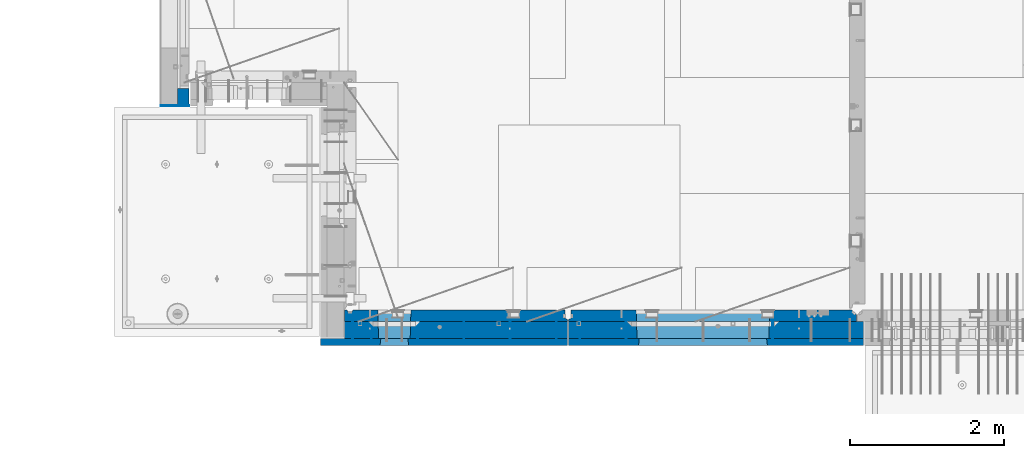
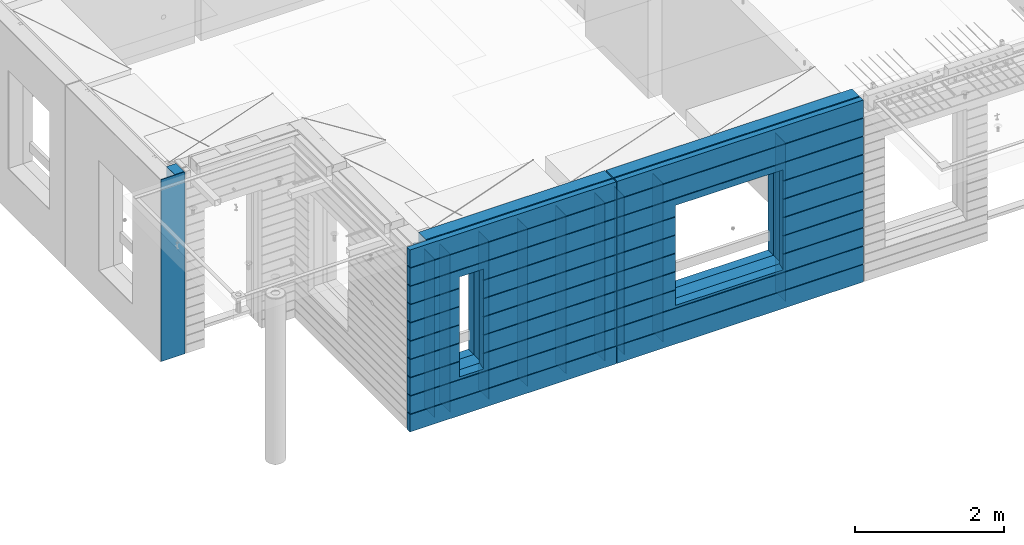
# One storey, part 227 of 352: 17 walls, 3 elements without a shape of their own.
"""IFC2X3 building model written with IfcOpenShell, lengths in millimetres."""

from ifc_helpers import new_model, si_unit, frame, origin_with_axes, place, context, subcontext, project, spatial, faceted_brep, material, type_object, element, aggregate, save


model = new_model("IFC2X3")

# Units and contexts
model_context = context("Model", 3, precision=1e-05, world=origin_with_axes())
body_context = subcontext(model_context, "Body", "Model", "MODEL_VIEW")
ifc_project = project(units=[si_unit("LENGTHUNIT", "METRE", prefix="MILLI"), si_unit("AREAUNIT", "SQUARE_METRE"), si_unit("VOLUMEUNIT", "CUBIC_METRE"), si_unit("MASSUNIT", "GRAM", prefix="KILO"), si_unit("TIMEUNIT", "SECOND"), si_unit("PLANEANGLEUNIT", "RADIAN"), si_unit("SOLIDANGLEUNIT", "STERADIAN"), si_unit("THERMODYNAMICTEMPERATUREUNIT", "DEGREE_CELSIUS"), si_unit("LUMINOUSINTENSITYUNIT", "LUMEN")], contexts=[model_context])

# Site, building, storey
site_placement = place(None, origin_with_axes())
site = spatial("IfcSite", under=ifc_project, at=site_placement, CompositionType="ELEMENT")
building_placement = place(site_placement, origin_with_axes())
building = spatial("IfcBuilding", under=site, at=building_placement, CompositionType="ELEMENT")
storey_placement = place(building_placement, origin_with_axes())
storey = spatial("IfcBuildingStorey", under=building, at=storey_placement, Name="6", CompositionType="ELEMENT", Elevation=0.0)

# Assembly, walls
assembly_1_placement = place(storey_placement, origin_with_axes())
assembly_1 = element("IfcElementAssembly", 1, at=assembly_1_placement, inside=storey, AssemblyPlace="NOTDEFINED", PredefinedType="REINFORCEMENT_UNIT")
ifc_material_1 = material(Name="Undefined")
wall_type_1 = type_object("IfcWallType", PredefinedType="NOTDEFINED")
wall_1_placement = place(assembly_1_placement, frame((10122.5, 7880.0, 98115.0), z_axis=(0.0, 0.0, 1.0), x_axis=(0.0, -1.0, 0.0)))
wall_1 = element("IfcWall", 2, at=wall_1_placement, type_object=wall_type_1, material=ifc_material_1, Name="(PD)", context=body_context, shape_type="Brep", body=[
    faceted_brep([(0.0, 5.0, -1300.0), (0.0, 5.0, 1300.0), (280.0, 5.0, 1300.0), (280.0, 5.0, -1300.0), (0.0, -5.0, 1300.0), (280.0, -5.0, 1300.0), (0.0, -5.0, -1300.0), (280.0, -5.0, -1300.0)], [[[0, 1, 2, 3]], [[1, 4, 5, 2]], [[4, 6, 7, 5]], [[6, 0, 3, 7]], [[5, 7, 3, 2]], [[6, 4, 1, 0]]]),
])
wall_2_placement = place(assembly_1_placement, frame((10362.5, 7880.0, 98115.0), z_axis=(0.0, 0.0, 1.0), x_axis=(0.0, -1.0, 0.0)))
wall_2 = element("IfcWall", 3, at=wall_2_placement, type_object=wall_type_1, material=ifc_material_1, Name="(PD)", context=body_context, shape_type="Brep", body=[
    faceted_brep([(0.0, 5.0, -1300.0), (0.0, 5.0, 1300.0), (280.0, 5.0, 1300.0), (280.0, 5.0, -1300.0), (0.0, -5.0, 1300.0), (280.0, -5.0, 1300.0), (0.0, -5.0, -1300.0), (280.0, -5.0, -1300.0)], [[[0, 1, 2, 3]], [[1, 4, 5, 2]], [[4, 6, 7, 5]], [[6, 0, 3, 7]], [[5, 7, 3, 2]], [[6, 4, 1, 0]]]),
])
wall_3_placement = place(assembly_1_placement, frame((10962.5, 7880.0, 98115.0), z_axis=(0.0, 0.0, 1.0), x_axis=(0.0, -1.0, 0.0)))
wall_3 = element("IfcWall", 4, at=wall_3_placement, type_object=wall_type_1, material=ifc_material_1, Name="(PD)", context=body_context, shape_type="Brep", body=[
    faceted_brep([(0.0, 5.0, -1300.0), (0.0, 5.0, 1300.0), (280.0, 5.0, 1300.0), (280.0, 5.0, -1300.0), (0.0, -5.0, 1300.0), (280.0, -5.0, 1300.0), (0.0, -5.0, -1300.0), (280.0, -5.0, -1300.0)], [[[0, 1, 2, 3]], [[1, 4, 5, 2]], [[4, 6, 7, 5]], [[6, 0, 3, 7]], [[5, 7, 3, 2]], [[6, 4, 1, 0]]]),
])
wall_4_placement = place(assembly_1_placement, frame((11562.5, 7880.0, 98115.0), z_axis=(0.0, 0.0, 1.0), x_axis=(0.0, -1.0, 0.0)))
wall_4 = element("IfcWall", 5, at=wall_4_placement, type_object=wall_type_1, material=ifc_material_1, Name="(PD)", context=body_context, shape_type="Brep", body=[
    faceted_brep([(0.0, 5.0, -1300.0), (0.0, 5.0, 1300.0), (280.0, 5.0, 1300.0), (280.0, 5.0, -1300.0), (0.0, -5.0, 1300.0), (280.0, -5.0, 1300.0), (0.0, -5.0, -1300.0), (280.0, -5.0, -1300.0)], [[[0, 1, 2, 3]], [[1, 4, 5, 2]], [[4, 6, 7, 5]], [[6, 0, 3, 7]], [[5, 7, 3, 2]], [[6, 4, 1, 0]]]),
])
wall_5_placement = place(assembly_1_placement, frame((12162.5, 7880.0, 98115.0), z_axis=(0.0, 0.0, 1.0), x_axis=(0.0, -1.0, 0.0)))
wall_5 = element("IfcWall", 6, at=wall_5_placement, type_object=wall_type_1, material=ifc_material_1, Name="(PD)", context=body_context, shape_type="Brep", body=[
    faceted_brep([(0.0, 5.0, -1300.0), (0.0, 5.0, 1300.0), (280.0, 5.0, 1300.0), (280.0, 5.0, -1300.0), (0.0, -5.0, 1300.0), (280.0, -5.0, 1300.0), (0.0, -5.0, -1300.0), (280.0, -5.0, -1300.0)], [[[0, 1, 2, 3]], [[1, 4, 5, 2]], [[4, 6, 7, 5]], [[6, 0, 3, 7]], [[5, 7, 3, 2]], [[6, 4, 1, 0]]]),
])
wall_6_placement = place(assembly_1_placement, frame((12762.5, 7880.0, 98115.0), z_axis=(0.0, 0.0, 1.0), x_axis=(0.0, -1.0, 0.0)))
wall_6 = element("IfcWall", 7, at=wall_6_placement, type_object=wall_type_1, material=ifc_material_1, Name="(PD)", context=body_context, shape_type="Brep", body=[
    faceted_brep([(0.0, 5.0, -1300.0), (0.0, 5.0, 1300.0), (280.0, 5.0, 1300.0), (280.0, 5.0, -1300.0), (0.0, -5.0, 1300.0), (280.0, -5.0, 1300.0), (0.0, -5.0, -1300.0), (280.0, -5.0, -1300.0)], [[[0, 1, 2, 3]], [[1, 4, 5, 2]], [[4, 6, 7, 5]], [[6, 0, 3, 7]], [[5, 7, 3, 2]], [[6, 4, 1, 0]]]),
])

assembly_2_placement = place(storey_placement, origin_with_axes())
assembly_2 = element("IfcElementAssembly", 8, at=assembly_2_placement, inside=storey, AssemblyPlace="NOTDEFINED", PredefinedType="REINFORCEMENT_UNIT")
wall_7_placement = place(assembly_2_placement, frame((13665.0, 7880.0, 98115.0), z_axis=(0.0, 0.0, 1.0), x_axis=(0.0, -1.0, 0.0)))
wall_7 = element("IfcWall", 9, at=wall_7_placement, type_object=wall_type_1, material=ifc_material_1, Name="(PD)", context=body_context, shape_type="Brep", body=[
    faceted_brep([(0.0, 5.0, -1300.0), (0.0, 5.0, 1300.0), (280.0, 5.0, 1300.0), (280.0, 5.0, -1300.0), (0.0, -5.0, 1300.0), (280.0, -5.0, 1300.0), (0.0, -5.0, -1300.0), (280.0, -5.0, -1300.0)], [[[0, 1, 2, 3]], [[1, 4, 5, 2]], [[4, 6, 7, 5]], [[6, 0, 3, 7]], [[5, 7, 3, 2]], [[6, 4, 1, 0]]]),
])
wall_8_placement = place(assembly_2_placement, frame((13065.0, 7880.0, 98115.0), z_axis=(0.0, 0.0, 1.0), x_axis=(0.0, -1.0, 0.0)))
wall_8 = element("IfcWall", 10, at=wall_8_placement, type_object=wall_type_1, material=ifc_material_1, Name="(PD)", context=body_context, shape_type="Brep", body=[
    faceted_brep([(0.0, 5.0, -1300.0), (0.0, 5.0, 1300.0), (280.0, 5.0, 1300.0), (280.0, 5.0, -1300.0), (0.0, -5.0, 1300.0), (280.0, -5.0, 1300.0), (0.0, -5.0, -1300.0), (280.0, -5.0, -1300.0)], [[[0, 1, 2, 3]], [[1, 4, 5, 2]], [[4, 6, 7, 5]], [[6, 0, 3, 7]], [[5, 7, 3, 2]], [[6, 4, 1, 0]]]),
])
wall_9_placement = place(assembly_2_placement, frame((15565.0, 7880.0, 98115.0), z_axis=(0.0, 0.0, 1.0), x_axis=(0.0, -1.0, 0.0)))
wall_9 = element("IfcWall", 11, at=wall_9_placement, type_object=wall_type_1, material=ifc_material_1, Name="(PD)", context=body_context, shape_type="Brep", body=[
    faceted_brep([(0.0, 5.0, -1300.0), (0.0, 5.0, 1300.0), (280.0, 5.0, 1300.0), (280.0, 5.0, -1300.0), (0.0, -5.0, 1300.0), (280.0, -5.0, 1300.0), (0.0, -5.0, -1300.0), (280.0, -5.0, -1300.0)], [[[0, 1, 2, 3]], [[1, 4, 5, 2]], [[4, 6, 7, 5]], [[6, 0, 3, 7]], [[5, 7, 3, 2]], [[6, 4, 1, 0]]]),
])

# Assembly, wall
assembly_3_placement = place(storey_placement, origin_with_axes())
assembly_3 = element("IfcElementAssembly", 12, at=assembly_3_placement, inside=storey, AssemblyPlace="NOTDEFINED", PredefinedType="REINFORCEMENT_UNIT")
ifc_material_2 = material()
wall_type_2 = type_object("IfcWallType", PredefinedType="NOTDEFINED")
wall_10_placement = place(assembly_3_placement, frame((8000.00051558999, 10765.0000158944, 98247.5), z_axis=(0.0, 0.0, 1.0), x_axis=(-0.999999999997437, -2.26400000064461e-06, 0.0)))
wall_10 = element("IfcWall", 13, at=wall_10_placement, type_object=wall_type_2, material=ifc_material_2, context=body_context, shape_type="Brep", body=[
    faceted_brep([(0.0, 110.0, -1492.5), (0.0, 110.0, 1492.5), (150.000694320282, 109.999999999998, 1492.5), (150.000694320282, 109.999999999998, -1492.5), (0.0, -110.0, 1492.5), (150.000694320282, -110.000000000004, 1492.5), (0.0, -110.0, -1492.5), (150.000694320282, -110.000000000004, -1492.5)], [[[0, 1, 2, 3]], [[1, 4, 5, 2]], [[4, 6, 7, 5]], [[6, 0, 3, 7]], [[5, 7, 3, 2]], [[6, 4, 1, 0]]]),
])

# Wall
ifc_material_3 = material(Name="COS5gt")
wall_11_placement = place(assembly_1_placement, frame((12912.5, 7740.0, 98247.5), z_axis=(0.0, 0.0, 1.0), x_axis=(-1.0, 3.00000001838171e-08, 0.0)))
wall_11 = element("IfcWall", 14, at=wall_11_placement, type_object=wall_type_2, material=ifc_material_3, context=body_context, shape_type="Brep", body=[
    faceted_brep([(7.5, 90.0, 1442.5), (2897.5, 90.0, 1442.5), (2897.5, 110.0, 1442.5), (7.5, 110.0, 1442.5), (7.5, 90.0, 1492.5), (2897.5, 90.0, 1492.5), (7.5, -110.0, 1492.5), (2897.5, -110.0, 1492.5), (2897.5, -110.0, -1492.5), (2897.5, 90.0, -1492.5), (2897.5, 90.0, -1442.5), (2897.5, 110.0, -1442.5), (7.5, 110.0, -1442.5), (7.5, 90.0, -1442.5), (2047.50059444406, 110.0, -807.5), (2077.50059444406, 110.0, -807.5), (2427.50059444406, 110.0, -807.5), (2457.50059444406, 110.0, -807.5), (2457.50059444406, 110.0, -802.5), (2457.50059444406, 110.0, 807.5), (2047.50059444406, 110.0, 807.5), (2047.50059444406, 110.0, -802.5), (2041.55464849811, -110.0, -813.445945945947), (2041.55464849811, -110.0, 813.445945945947), (2463.44654039001, -110.0, -813.445945945947), (2463.44654039001, -110.0, 813.445945945947), (7.5, -110.0, -1492.5), (7.5, 90.0, -1492.5)], [[[0, 1, 2, 3]], [[4, 5, 1, 0]], [[6, 7, 5, 4]], [[2, 1, 5, 7, 8, 9, 10, 11]], [[12, 11, 10, 13]], [[3, 2, 11, 12], [14, 15, 16, 17, 18, 19, 20, 21]], [[22, 14, 21, 20, 23]], [[24, 17, 16, 15, 14, 22]], [[18, 17, 24, 25, 19]], [[23, 20, 19, 25]], [[6, 26, 8, 7], [24, 22, 23, 25]], [[8, 26, 27, 9]], [[13, 10, 9, 27]], [[26, 6, 4, 0, 3, 12, 13, 27]]]),
])

wall_12_placement = place(assembly_2_placement, frame((16740.0, 7740.0, 98247.5), z_axis=(0.0, 0.0, 1.0), x_axis=(-1.0, 3.00000001838171e-08, 0.0)))
wall_12 = element("IfcWall", 15, at=wall_12_placement, type_object=wall_type_2, material=ifc_material_3, context=body_context, shape_type="Brep", body=[
    faceted_brep([(0.0, 90.0, 1442.5), (3820.0, 90.0, 1442.5), (3820.0, 110.0, 1442.5), (0.0, 110.0, 1442.5), (0.0, 90.0, 1492.5), (3820.0, 90.0, 1492.5), (0.0, -110.0, 1492.5), (3820.0, -110.0, 1492.5), (3820.0, -110.0, -1492.5), (3820.0, 90.0, -1492.5), (3820.0, 90.0, -1442.5), (3820.0, 110.0, -1442.5), (0.0, 110.0, -1442.5), (0.0, 90.0, -1442.5), (1224.99975425761, 110.0, -807.5), (1254.99975425761, 110.0, -807.5), (2904.99975425761, 110.0, -807.5), (2934.99975425761, 110.0, -807.5), (2934.99975425761, 110.0, -802.5), (2934.99975425761, 110.0, 807.5), (1224.99975425761, 110.0, 807.5), (1224.99975425761, 110.0, -802.5), (1219.05380831167, -110.0, -813.445945945947), (1219.05380831167, -110.0, 813.445945945947), (2940.94570020356, -110.0, -813.445945945947), (2940.94570020356, -110.0, 813.445945945947), (0.0, -110.0, -1492.5), (0.0, 90.0, -1492.5)], [[[0, 1, 2, 3]], [[4, 5, 1, 0]], [[6, 7, 5, 4]], [[2, 1, 5, 7, 8, 9, 10, 11]], [[12, 11, 10, 13]], [[3, 2, 11, 12], [14, 15, 16, 17, 18, 19, 20, 21]], [[22, 14, 21, 20, 23]], [[24, 17, 16, 15, 14, 22]], [[18, 17, 24, 25, 19]], [[23, 20, 19, 25]], [[6, 26, 8, 7], [24, 22, 23, 25]], [[8, 26, 27, 9]], [[13, 10, 9, 27]], [[27, 26, 6, 4, 0, 3, 12, 13]]]),
])

ifc_material_4 = material(Name="CONCRETE/C30/37")
wall_type_3 = type_object("IfcWallType", PredefinedType="NOTDEFINED")
wall_13_placement = place(assembly_1_placement, frame((12912.5, 7587.5, 98247.5), z_axis=(0.0, 0.0, 1.0), x_axis=(-1.0, 3.00000001838171e-08, 0.0)))
wall_13 = element("IfcWall", 16, at=wall_13_placement, type_object=wall_type_3, material=ifc_material_4, context=body_context, shape_type="Brep", body=[
    faceted_brep([(3207.5, -42.5, 1193.0000011433), (3207.5, 42.5, 1192.99999994476), (3197.49999925687, 32.4999992501671, 1194.99999999921), (3197.49999396174, -42.5, 1195.00000105656), (3197.49999368253, -42.5, 1205.00000145777), (3197.49999897767, 32.4999991121604, 1205.00000040043), (3207.5, 42.5, 1206.99999988925), (3207.5, -42.5, 1207.0000010878), (7.4999999999709, -42.5, -1492.5), (7.4999999999709, 42.5, -1492.5), (3207.5, 42.5, -1492.5), (3207.5, -42.5, -1492.5), (7.4999999999709, 42.5, -1207.00000005524), (3207.5, 42.5, -1207.00000005524), (3207.5, -42.5, -1206.9999988567), (3197.49999925687, 32.4999992501671, -1205.00000000079), (3197.49999396174, -42.5, -1204.99999894344), (7.4999999999709, 32.4999992501671, -1205.00000000079), (7.4999999999709, 32.4999991121604, -1194.99999959957), (3197.49999897767, 32.4999991121604, -1194.99999959957), (3197.49999368253, -42.5, -1194.99999854223), (3207.5, -42.5, -1192.9999989122), (3207.5, 42.5, -1193.00000011075), (3207.5, 42.5, -907.000000055239), (3207.5, -42.5, -906.9999988567), (7.4999999999709, 42.5, -1193.00000011075), (7.4999999999709, 42.5, -907.000000055239), (7.4999999999709, 32.4999992501671, -905.000000000786), (3197.49999925687, 32.4999992501671, -905.000000000786), (3197.49999396174, -42.5, -904.999998943444), (3197.49999897767, 32.4999991121604, -894.999999599575), (3197.49999368253, -42.5, -894.999998542233), (7.4999999999709, 32.4999991121604, -894.999999599575), (7.4999999999709, 42.5, -893.000000110755), (3207.5, 42.5, -893.000000110755), (3207.5, -42.5, -892.999998912201), (3207.5, 42.5, -607.000000055239), (3207.5, -42.5, -606.9999988567), (3197.49999925687, 32.4999992501671, -605.000000000786), (3197.49999396174, -42.5, -604.999998943444), (2437.50059444406, 42.5, -607.000000055239), (2436.32412376761, 32.4999992501671, -605.000000000786), (2436.32412375137, 32.4999991121604, -594.999999599575), (3197.49999897767, 32.4999991121604, -594.999999599575), (3197.49999368253, -42.5, -594.999998542233), (3207.5, 42.5, -593.000000110755), (3207.5, -42.5, -592.999998912201), (2437.50059444406, 42.5, -593.000000110755), (3207.5, 42.5, -307.000000055239), (2437.50059444406, 42.5, -307.000000055239), (3207.5, -42.5, -306.9999988567), (3197.49999925687, 32.4999992501671, -305.000000000786), (3197.49999396174, -42.5, -304.999998943444), (2436.32412376761, 32.4999992501671, -305.000000000786), (2436.32412375137, 32.4999991121604, -294.999999599575), (3197.49999897767, 32.4999991121604, -294.999999599575), (3197.49999368253, -42.5, -294.999998542233), (3207.5, 42.5, -293.000000110755), (3207.5, -42.5, -292.999998912201), (2437.50059444406, 42.5, -293.000000110755), (3207.5, 42.5, -7.00000005523907), (2437.50059444406, 42.5, -7.00000005523907), (3207.5, -42.5, -6.99999885669968), (3197.49999925687, 32.4999992501671, -5.0000000007858), (3197.49999396174, -42.5, -4.99999894344364), (2436.32412376761, 32.4999992501671, -5.0000000007858), (2436.32412375137, 32.4999991121604, 5.00000040042505), (3197.49999897767, 32.4999991121604, 5.00000040042505), (3197.49999368253, -42.5, 5.00000145776721), (3207.5, 42.5, 6.99999988924537), (3207.5, -42.5, 7.00000108779932), (2437.50059444406, 42.5, 6.99999988924537), (3207.5, 42.5, 292.999999944761), (2437.50059444406, 42.5, 292.999999944761), (3207.5, -42.5, 293.0000011433), (3197.49999925687, 32.4999992501671, 294.999999999214), (3197.49999396174, -42.5, 295.000001056556), (2436.32412376761, 32.4999992501671, 294.999999999214), (2436.32412375137, 32.4999991121604, 305.000000400425), (3197.49999897767, 32.4999991121604, 305.000000400425), (3197.49999368253, -42.5, 305.000001457767), (3207.5, -42.5, 307.000001087799), (3207.5, 42.5, 306.999999889245), (3207.5, 42.5, 592.999999944761), (3207.5, -42.5, 593.0000011433), (2437.50059444406, 42.5, 306.999999889245), (2437.50059444406, 42.5, 592.999999944761), (2436.32412376761, 32.4999992501671, 594.999999999214), (3197.49999925687, 32.4999992501671, 594.999999999214), (3197.49999396174, -42.5, 595.000001056556), (3197.49999897767, 32.4999991121604, 605.000000400425), (3197.49999368253, -42.5, 605.000001457767), (2436.32412375137, 32.4999991121604, 605.000000400425), (2437.50059444406, 42.5, 606.999999889245), (3207.5, 42.5, 606.999999889245), (3207.5, -42.5, 607.000001087799), (3207.5, 42.5, 892.999999944761), (3207.5, -42.5, 893.0000011433), (3197.49999925687, 32.4999992501671, 894.999999999214), (3197.49999396174, -42.5, 895.000001056556), (7.4999999999709, 42.5, 892.999999944761), (7.49999999998181, 32.4999992501671, 894.999999999214), (7.49999999998181, 32.4999991121604, 905.000000400425), (3197.49999897767, 32.4999991121604, 905.000000400425), (3197.49999368253, -42.5, 905.000001457767), (3207.5, -42.5, 907.000001087799), (3207.5, 42.5, 906.999999889245), (7.4999999999709, 42.5, 906.999999889245), (7.4999999999709, 42.5, 1192.99999994476), (7.49999999998363, 32.4999992501671, 1194.99999999921), (7.4999999999709, 42.5, 1492.5), (7.4999999999709, -42.5, 1492.5), (3207.5, -42.5, 1492.5), (3207.5, 42.5, 1492.5), (7.4999999999709, 42.5, 1206.99999988925), (7.49999999998363, 32.4999991121604, 1205.00000040043), (7.4999999999709, 42.5, 606.999999889245), (7.49999999997999, 32.4999991121604, 605.000000400425), (7.49999999997999, 32.4999992501671, 594.999999999214), (7.4999999999709, 42.5, 592.999999944761), (7.4999999999709, 42.5, 306.999999889245), (7.49999999997453, 32.4999991121604, 305.000000400425), (7.49999999997453, 32.4999992501671, 294.999999999214), (7.4999999999709, 42.5, 292.999999944761), (7.4999999999709, 42.5, 6.99999988924537), (7.4999999999709, 32.4999991121604, 5.00000040042505), (7.4999999999709, 32.4999992501671, -5.0000000007858), (7.4999999999709, 42.5, -7.00000005523907), (7.4999999999709, 42.5, -293.000000110755), (7.4999999999709, 32.4999991121604, -294.999999599575), (7.4999999999709, 32.4999992501671, -305.000000000786), (7.4999999999709, 42.5, -307.000000055239), (7.4999999999709, 42.5, -593.000000110755), (7.49999999996908, 32.4999991121604, -594.999999599575), (7.49999999996908, 32.4999992501671, -605.000000000786), (7.4999999999709, 42.5, -607.000000055239), (2068.67706513675, 32.4999991121604, 605.000000400425), (2068.67706512051, 32.4999992501671, 594.999999999214), (2067.50059444406, 42.5, 592.999999944761), (2067.50059444406, 42.5, 306.999999889245), (2068.67706513675, 32.4999991121604, 305.000000400425), (2068.67706512051, 32.4999992501671, 294.999999999214), (2067.50059444406, 42.5, 292.999999944761), (2067.50059444406, 42.5, 6.99999988924537), (2068.67706513675, 32.4999991121604, 5.00000040042505), (2068.67706512051, 32.4999992501671, -5.0000000007858), (2067.50059444406, 42.5, -7.00000005523907), (2067.50059444406, 42.5, -293.000000110755), (2068.67706513675, 32.4999991121604, -294.999999599575), (2068.67706512051, 32.4999992501671, -305.000000000786), (2067.50059444406, 42.5, -307.000000055239), (2067.50059444406, 42.5, -593.000000110755), (2068.67706513675, 32.4999991121604, -594.999999599575), (2068.67706512051, 32.4999992501671, -605.000000000786), (2067.50059444406, 42.5, -607.000000055239), (2437.50059444406, 42.5, -857.5), (2067.50059444406, 42.5, -857.5), (2077.50059444406, -42.5, -807.5), (2427.50059444406, -42.5, -807.5), (2427.50059444406, -42.5, 782.5), (2427.50059444406, -42.5, 787.5), (2437.50059444406, 42.5, 782.5), (2427.50059444406, 42.5, 782.5), (2077.50059444406, 42.5, 782.5), (2067.50059444406, 42.5, 782.5), (2067.50059444406, 42.5, 606.999999889245), (2077.50059444406, -42.5, 787.5), (2077.50059444406, -42.5, 782.5)], [[[0, 1, 2, 3]], [[4, 5, 6, 7]], [[3, 2, 5, 4]], [[8, 9, 10, 11]], [[10, 9, 12, 13]], [[11, 10, 13, 14]], [[14, 13, 15, 16]], [[12, 17, 15, 13]], [[17, 18, 19, 15]], [[16, 15, 19, 20]], [[21, 22, 23, 24]], [[20, 19, 22, 21]], [[18, 25, 22, 19]], [[22, 25, 26, 23]], [[26, 27, 28, 23]], [[24, 23, 28, 29]], [[29, 28, 30, 31]], [[27, 32, 30, 28]], [[32, 33, 34, 30]], [[31, 30, 34, 35]], [[35, 34, 36, 37]], [[37, 36, 38, 39]], [[40, 41, 38, 36]], [[41, 42, 43, 38]], [[39, 38, 43, 44]], [[44, 43, 45, 46]], [[42, 47, 45, 43]], [[48, 45, 47, 49]], [[46, 45, 48, 50]], [[50, 48, 51, 52]], [[49, 53, 51, 48]], [[53, 54, 55, 51]], [[52, 51, 55, 56]], [[56, 55, 57, 58]], [[54, 59, 57, 55]], [[60, 57, 59, 61]], [[58, 57, 60, 62]], [[62, 60, 63, 64]], [[61, 65, 63, 60]], [[65, 66, 67, 63]], [[64, 63, 67, 68]], [[68, 67, 69, 70]], [[66, 71, 69, 67]], [[72, 69, 71, 73]], [[70, 69, 72, 74]], [[74, 72, 75, 76]], [[73, 77, 75, 72]], [[77, 78, 79, 75]], [[76, 75, 79, 80]], [[81, 82, 83, 84]], [[80, 79, 82, 81]], [[78, 85, 82, 79]], [[83, 82, 85, 86]], [[86, 87, 88, 83]], [[84, 83, 88, 89]], [[89, 88, 90, 91]], [[87, 92, 90, 88]], [[92, 93, 94, 90]], [[91, 90, 94, 95]], [[95, 94, 96, 97]], [[97, 96, 98, 99]], [[100, 101, 98, 96]], [[101, 102, 103, 98]], [[99, 98, 103, 104]], [[105, 106, 1, 0]], [[104, 103, 106, 105]], [[102, 107, 106, 103]], [[106, 107, 108, 1]], [[108, 109, 2, 1]], [[110, 111, 112, 113]], [[113, 112, 7, 6]], [[110, 113, 6, 114]], [[115, 114, 6, 5]], [[109, 115, 5, 2]], [[108, 107, 102, 101, 100, 116, 117, 118, 119, 120, 121, 122, 123, 124, 125, 126, 127, 128, 129, 130, 131, 132, 133, 134, 135, 33, 32, 27, 26, 25, 18, 17, 12, 9, 8, 111, 110, 114, 115, 109]], [[118, 117, 136, 137]], [[119, 118, 137, 138]], [[120, 119, 138, 139]], [[121, 120, 139, 140]], [[122, 121, 140, 141]], [[123, 122, 141, 142]], [[124, 123, 142, 143]], [[125, 124, 143, 144]], [[126, 125, 144, 145]], [[127, 126, 145, 146]], [[128, 127, 146, 147]], [[129, 128, 147, 148]], [[130, 129, 148, 149]], [[131, 130, 149, 150]], [[132, 131, 150, 151]], [[133, 132, 151, 152]], [[134, 133, 152, 153]], [[135, 134, 153, 154]], [[155, 40, 36, 34, 33, 135, 154, 156]], [[156, 157, 158, 155]], [[159, 160, 161, 93, 92, 87, 86, 85, 78, 77, 73, 71, 66, 65, 61, 59, 54, 53, 49, 47, 42, 41, 40, 155, 158]], [[116, 100, 96, 94, 93, 161, 162, 163, 164, 165]], [[117, 116, 165, 136]], [[164, 166, 167, 157, 156, 154, 153, 152, 151, 150, 149, 148, 147, 146, 145, 144, 143, 142, 141, 140, 139, 138, 137, 136, 165]], [[163, 162, 161, 160, 166, 164]], [[112, 111, 8, 11, 14, 16, 20, 21, 24, 29, 31, 35, 37, 39, 44, 46, 50, 52, 56, 58, 62, 64, 68, 70, 74, 76, 80, 81, 84, 89, 91, 95, 97, 99, 104, 105, 0, 3, 4, 7], [159, 158, 157, 167, 166, 160]]]),
])

wall_14_placement = place(assembly_2_placement, frame((16740.0, 7587.5, 98247.5), z_axis=(0.0, 0.0, 1.0), x_axis=(-1.0, 3.00000001838171e-08, 0.0)))
wall_14 = element("IfcWall", 17, at=wall_14_placement, type_object=wall_type_3, material=ifc_material_4, context=body_context, shape_type="Brep", body=[
    faceted_brep([(3820.00000000003, 42.5, 606.999999889245), (3820.00000000002, 32.4999991121731, 605.00000040044), (2913.82328356493, 32.4999991121731, 605.00000040044), (2914.99975425761, 42.5, 606.999999889245), (3820.00000000002, 32.4999992501716, 594.999999999243), (2913.82328358116, 32.4999992501716, 594.999999999243), (3820.00000000003, 42.5, 592.999999944761), (2914.99975425761, 42.5, 592.999999944761), (3820.00000000003, 42.5, 306.999999889245), (2914.99975425761, 42.5, 306.999999889245), (3820.00000000002, 32.4999991121731, 305.00000040044), (2913.82328356493, 32.4999991121731, 305.00000040044), (3820.00000000002, 32.4999992501716, 294.999999999243), (2913.82328358116, 32.4999992501716, 294.999999999243), (3820.00000000003, 42.5, 292.999999944761), (2914.99975425761, 42.5, 292.999999944761), (3820.00000000003, 42.5, 6.99999988924537), (2914.99975425761, 42.5, 6.99999988924537), (3820.00000000003, 32.4999991121731, 5.0000004004396), (2913.82328356493, 32.4999991121731, 5.0000004004396), (3820.00000000003, 32.4999992501716, -5.0000000007567), (2913.82328358116, 32.4999992501716, -5.0000000007567), (3820.00000000003, 42.5, -7.00000005523907), (2914.99975425761, 42.5, -7.00000005523907), (3820.00000000003, 42.5, -293.000000110755), (2914.99975425761, 42.5, -293.000000110755), (3820.00000000003, 32.4999991121731, -294.99999959956), (2913.82328356493, 32.4999991121731, -294.99999959956), (3820.00000000003, 32.4999992501716, -305.000000000757), (2913.82328358116, 32.4999992501716, -305.000000000757), (3820.00000000003, 42.5, -307.000000055239), (2914.99975425761, 42.5, -307.000000055239), (3820.00000000003, 42.5, -593.000000110755), (2914.99975425761, 42.5, -593.000000110755), (3820.00000000003, 32.4999991121731, -594.99999959956), (2913.82328356493, 32.4999991121731, -594.99999959956), (3820.00000000003, 32.4999992501716, -605.000000000757), (2913.82328358116, 32.4999992501716, -605.000000000757), (3820.00000000003, 42.5, -607.000000055239), (2914.99975425761, 42.5, -607.000000055239), (0.0, -42.5, -1492.5), (0.0, 42.5, -1492.5), (3820.00000000003, 42.5, -1492.5), (3820.00000000003, -42.5, -1492.5), (0.0, 42.5, -1207.00000005524), (3820.00000000003, 42.5, -1207.00000005524), (0.0, 32.4999992507037, -1205.00000000074), (3820.00000000003, 32.4999992501716, -1205.00000000076), (0.0, 32.4999991127006, -1194.99999959956), (3820.00000000003, 32.4999991121731, -1194.99999959956), (0.0, 42.5, -1193.00000011075), (3820.00000000003, 42.5, -1193.00000011075), (0.0, 42.5, -907.000000055239), (3820.00000000003, 42.5, -907.000000055239), (0.0, 32.4999992507037, -905.000000000742), (3820.00000000003, 32.4999992501716, -905.000000000757), (0.0, 32.4999991127006, -894.99999959956), (3820.00000000003, 32.4999991121731, -894.99999959956), (0.0, 42.5, -893.000000110755), (3820.00000000003, 42.5, -893.000000110755), (3.63797880709171e-12, 32.4999992507037, 594.999999999258), (3.63797880709171e-12, 32.4999991127006, 605.00000040044), (1246.1762249503, 32.4999991121731, 605.00000040044), (1246.17622493406, 32.4999992501716, 594.999999999243), (0.0, 42.5, 592.999999944761), (1244.99975425761, 42.5, 592.999999944761), (0.0, 42.5, 306.999999889245), (1244.99975425761, 42.5, 306.999999889245), (-3.63797880709171e-12, 32.4999991127006, 305.00000040044), (1246.1762249503, 32.4999991121731, 305.00000040044), (-3.63797880709171e-12, 32.4999992507037, 294.999999999258), (1246.17622493406, 32.4999992501716, 294.999999999243), (0.0, 42.5, 292.999999944761), (1244.99975425761, 42.5, 292.999999944761), (0.0, 42.5, 6.99999988924537), (1244.99975425761, 42.5, 6.99999988924537), (0.0, 32.4999991127006, 5.0000004004396), (1246.1762249503, 32.4999991121731, 5.0000004004396), (0.0, 32.4999992507037, -5.00000000074215), (1246.17622493406, 32.4999992501716, -5.0000000007567), (0.0, 42.5, -7.00000005523907), (1244.99975425761, 42.5, -7.00000005523907), (0.0, 42.5, -293.000000110755), (1244.99975425761, 42.5, -293.000000110755), (0.0, 32.4999991127006, -294.99999959956), (1246.1762249503, 32.4999991121731, -294.99999959956), (0.0, 32.4999992507037, -305.000000000742), (1246.17622493406, 32.4999992501716, -305.000000000757), (0.0, 42.5, -307.000000055239), (1244.99975425761, 42.5, -307.000000055239), (0.0, 42.5, -593.000000110755), (1244.99975425761, 42.5, -593.000000110755), (3.63797880709171e-12, 32.4999991127006, -594.99999959956), (1246.1762249503, 32.4999991121731, -594.99999959956), (3.63797880709171e-12, 32.4999992507037, -605.000000000742), (1246.17622493406, 32.4999992501716, -605.000000000757), (0.0, 42.5, -607.000000055239), (1244.99975425761, 42.5, -607.000000055239), (2914.99975425761, 42.5, -857.5), (1244.99975425761, 42.5, -857.5), (1254.99975425761, -42.5, -807.5), (2904.99975425761, -42.5, -807.5), (2904.99975425761, -42.5, 782.5), (2904.99975425761, -42.5, 787.5), (2914.99975425761, 42.5, 782.5), (1254.99975425761, 42.5, 782.5), (2904.99975425761, 42.5, 782.5), (1254.99975425761, -42.5, 787.5), (1244.99975425761, 42.5, 782.5), (0.0, -42.5, 1492.5), (3820.00000000003, -42.5, 1492.5), (1254.99975425761, -42.5, 782.5), (0.0, 42.5, 1492.5), (3820.00000000003, 42.5, 1492.5), (3820.00000000003, 42.5, 1206.99999988925), (0.0, 42.5, 1206.99999988925), (3820.00000000002, 32.4999991121731, 1205.00000040044), (0.0, 32.4999991127006, 1205.00000040044), (3820.00000000003, 42.5, 892.999999944761), (3820.00000000002, 32.4999992501716, 894.999999999243), (3820.00000000002, 32.4999991121731, 905.00000040044), (3820.00000000003, 42.5, 906.999999889245), (3820.00000000003, 42.5, 1192.99999994476), (3820.00000000002, 32.4999992501716, 1194.99999999924), (0.0, 42.5, 906.999999889245), (0.0, 42.5, 1192.99999994476), (0.0, 32.4999992507037, 1194.99999999926), (0.0, 32.4999991127006, 905.00000040044), (0.0, 32.4999992507037, 894.999999999258), (0.0, 42.5, 892.999999944761), (0.0, 42.5, 606.999999889245), (1244.99975425761, 42.5, 606.999999889245)], [[[0, 1, 2, 3]], [[1, 4, 5, 2]], [[4, 6, 7, 5]], [[6, 8, 9, 7]], [[8, 10, 11, 9]], [[10, 12, 13, 11]], [[12, 14, 15, 13]], [[14, 16, 17, 15]], [[16, 18, 19, 17]], [[18, 20, 21, 19]], [[20, 22, 23, 21]], [[22, 24, 25, 23]], [[24, 26, 27, 25]], [[26, 28, 29, 27]], [[28, 30, 31, 29]], [[30, 32, 33, 31]], [[32, 34, 35, 33]], [[34, 36, 37, 35]], [[36, 38, 39, 37]], [[40, 41, 42, 43]], [[42, 41, 44, 45]], [[46, 47, 45, 44]], [[48, 49, 47, 46]], [[50, 51, 49, 48]], [[51, 50, 52, 53]], [[54, 55, 53, 52]], [[56, 57, 55, 54]], [[58, 59, 57, 56]], [[60, 61, 62, 63]], [[64, 60, 63, 65]], [[66, 64, 65, 67]], [[68, 66, 67, 69]], [[70, 68, 69, 71]], [[72, 70, 71, 73]], [[74, 72, 73, 75]], [[76, 74, 75, 77]], [[78, 76, 77, 79]], [[80, 78, 79, 81]], [[82, 80, 81, 83]], [[84, 82, 83, 85]], [[86, 84, 85, 87]], [[88, 86, 87, 89]], [[90, 88, 89, 91]], [[92, 90, 91, 93]], [[94, 92, 93, 95]], [[96, 94, 95, 97]], [[98, 39, 38, 59, 58, 96, 97, 99]], [[99, 100, 101, 98]], [[102, 103, 104, 3, 2, 5, 7, 9, 11, 13, 15, 17, 19, 21, 23, 25, 27, 29, 31, 33, 35, 37, 39, 98, 101]], [[105, 106, 104, 103, 107, 108]], [[109, 40, 43, 110], [102, 101, 100, 111, 107, 103]], [[112, 109, 110, 113]], [[112, 113, 114, 115]], [[115, 114, 116, 117]], [[113, 110, 43, 42, 45, 47, 49, 51, 53, 55, 57, 59, 38, 36, 34, 32, 30, 28, 26, 24, 22, 20, 18, 16, 14, 12, 10, 8, 6, 4, 1, 0, 118, 119, 120, 121, 122, 123, 116, 114]], [[121, 124, 125, 122]], [[126, 123, 122, 125]], [[117, 116, 123, 126]], [[125, 124, 127, 128, 129, 130, 61, 60, 64, 66, 68, 70, 72, 74, 76, 78, 80, 82, 84, 86, 88, 90, 92, 94, 96, 58, 56, 54, 52, 50, 48, 46, 44, 41, 40, 109, 112, 115, 117, 126]], [[61, 130, 131, 62]], [[108, 107, 111, 100, 99, 97, 95, 93, 91, 89, 87, 85, 83, 81, 79, 77, 75, 73, 71, 69, 67, 65, 63, 62, 131]], [[130, 129, 118, 0, 3, 104, 106, 105, 108, 131]], [[128, 119, 118, 129]], [[127, 120, 119, 128]], [[124, 121, 120, 127]]]),
])

ifc_material_5 = material(Name="CONCRETE/C25/30")
wall_type_4 = type_object("IfcWallType", PredefinedType="NOTDEFINED")
wall_15_placement = place(assembly_1_placement, frame((12912.5, 7925.0, 98112.5), z_axis=(0.0, 0.0, 1.0), x_axis=(-1.0, 3.00000001838171e-08, 0.0)))
wall_15 = element("IfcWall", 18, at=wall_15_placement, type_object=wall_type_4, material=ifc_material_5, context=body_context, shape_type="Brep", body=[
    faceted_brep([(2787.5, -75.0, 1357.5), (2787.5, -75.0, -1357.5), (2800.5, -55.0, -1357.5), (2800.5, -55.0, 1357.5), (2852.5, -55.0, 1357.5), (2802.5, -55.0, 1357.5), (2802.5, -55.0, -1357.5), (2852.5, -55.0, -1357.5), (2854.5, -55.0, -1357.5), (2854.5, -55.0, 1357.5), (2867.5, -75.0, -1357.5), (2867.5, -75.0, 1357.5), (2897.5, -75.0, -1357.5), (2897.5, -75.0, 1357.5), (2897.5, 75.0, -1357.5), (2897.5, 75.0, 1357.5), (40.0, -75.0, 1357.5), (7.4999999999709, 75.0, 1357.5), (7.5, 45.0, 1357.5), (40.0, 32.0, 1357.5), (7.4999999999709, 75.0, -1357.5), (7.4999999999709, 45.0, -1357.5), (40.0, 32.0, -1357.5), (40.0, -75.0, -1357.5), (2467.50059444406, -75.0, -682.5), (2037.50059444406, -75.0, -682.5), (2037.50059444406, -75.0, 952.5), (2467.50059444406, -75.0, 952.5), (2463.44654039001, 75.0, -678.445945945947), (2041.55464849811, 75.0, -678.445945945947), (2041.55464849811, 75.0, 948.445945945947), (2463.44654039001, 75.0, 948.445945945947)], [[[0, 1, 2, 3]], [[4, 5, 3, 2, 6, 7, 8, 9]], [[9, 8, 10, 11]], [[12, 13, 11, 10]], [[13, 12, 14, 15]], [[16, 0, 3, 5, 4, 9, 11, 13, 15, 17, 18, 19]], [[17, 20, 21, 18]], [[18, 21, 22, 19]], [[20, 14, 12, 10, 8, 7, 6, 2, 1, 23, 22, 21]], [[16, 19, 22, 23]], [[1, 0, 16, 23], [24, 25, 26, 27]], [[24, 28, 29, 25]], [[25, 29, 30, 26]], [[20, 17, 15, 14], [28, 31, 30, 29]], [[26, 30, 31, 27]], [[28, 24, 27, 31]]]),
])

aggregate(assembly_1, [wall_1, wall_2, wall_3, wall_4, wall_5, wall_6, wall_13, wall_11, wall_15])

wall_16_placement = place(assembly_2_placement, frame((16660.0, 7925.0, 98112.5), z_axis=(0.0, 0.0, 1.0), x_axis=(-1.0, 3.00000001838171e-08, 0.0)))
wall_16 = element("IfcWall", 19, at=wall_16_placement, type_object=wall_type_4, material=ifc_material_5, context=body_context, shape_type="Brep", body=[
    faceted_brep([(10.0, 75.0, 1357.5), (10.0, 75.0, -1357.5), (10.0, -15.0, -1357.5), (10.0, -15.0, 1357.5), (70.0, -75.0, -1357.5), (3740.00000000003, 75.0, -1357.5), (3740.00000000003, 45.0, -1357.5), (3707.5, 32.0, -1357.5), (3707.5, -75.0, -1357.5), (70.0, -75.0, 1357.5), (3740.00000000003, 45.0, 1357.5), (3740.00000000003, 75.0, 1357.5), (3707.5, -75.0, 1357.5), (3707.5, 32.0, 1357.5), (2864.99975425761, -75.0, -682.5), (1134.99975425761, -75.0, -682.5), (1134.99975425761, -75.0, 952.5), (2864.99975425761, -75.0, 952.5), (2860.94570020356, 75.0, -678.445945945947), (1139.05380831167, 75.0, -678.445945945947), (1139.05380831167, 75.0, 948.445945945947), (2860.94570020356, 75.0, 948.445945945947)], [[[0, 1, 2, 3]], [[4, 2, 1, 5, 6, 7, 8]], [[3, 2, 4, 9]], [[10, 11, 0, 3, 9, 12, 13]], [[5, 11, 10, 6]], [[13, 7, 6, 10]], [[12, 8, 7, 13]], [[9, 4, 8, 12], [14, 15, 16, 17]], [[14, 18, 19, 15]], [[15, 19, 20, 16]], [[1, 0, 11, 5], [18, 21, 20, 19]], [[16, 20, 21, 17]], [[18, 14, 17, 21]]]),
])

aggregate(assembly_2, [wall_7, wall_8, wall_9, wall_14, wall_12, wall_16])

wall_type_5 = type_object("IfcWallType", PredefinedType="NOTDEFINED")
wall_17_placement = place(assembly_3_placement, frame((8000.00033490857, 10650.0000304601, 98247.5), z_axis=(0.0, 0.0, 1.0), x_axis=(-1.0, 3.00000001838171e-08, 0.0)))
wall_17 = element("IfcWall", 20, at=wall_17_placement, type_object=wall_type_5, material=ifc_material_4, context=body_context, shape_type="Brep", body=[
    faceted_brep([(0.0, 5.0, -1492.5), (0.0, 5.0, 1492.5), (370.000694320092, 4.99999999999818, 1492.5), (370.000694320092, 4.99999999999818, -1492.5), (0.0, -5.0, 1492.5), (370.000694320092, -5.0, 1492.5), (0.0, -5.0, -1492.5), (370.000694320092, -5.0, -1492.5)], [[[0, 1, 2, 3]], [[1, 4, 5, 2]], [[4, 6, 7, 5]], [[6, 0, 3, 7]], [[5, 7, 3, 2]], [[6, 4, 1, 0]]]),
])

aggregate(assembly_3, [wall_17, wall_10])

save(model, "model.ifc")
